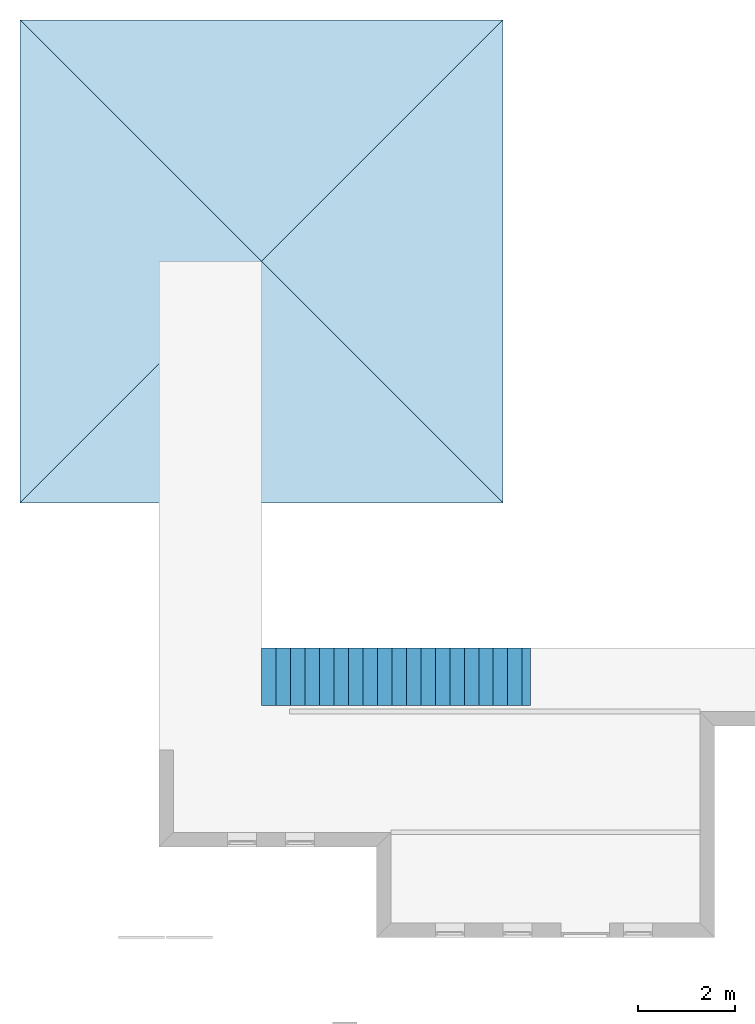
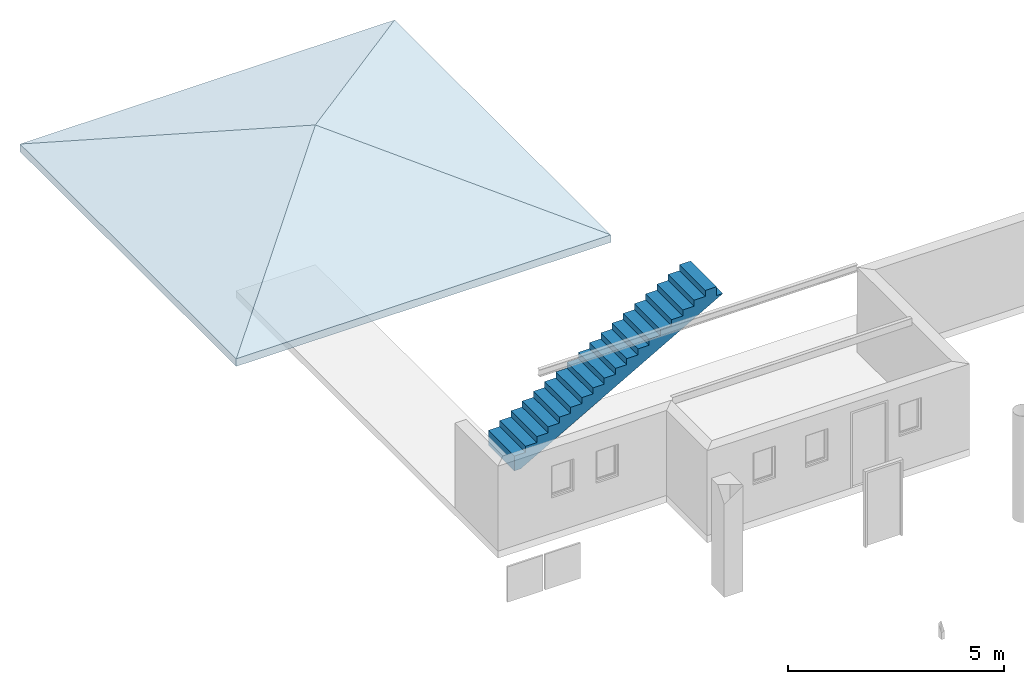
# One storey, part 4 of 5: 1 roof, 1 stair flight.
"""IFC4 building model written with IfcOpenShell, lengths in millimetres."""

from ifc_helpers import new_model, entity, si_unit, converted_unit, frame, origin_with_axes, origin_2d_with_axis, place, context, subcontext, project, spatial, polygons, source, transform, mapped, type_object, type_shapes, element, save


model = new_model("IFC4")

# Units and contexts
model_context = context("Model", 3, precision=1e-05, world=origin_with_axes())
plan_context = context("Plan", 2, precision=1e-05, world=origin_2d_with_axis())
body_context = subcontext(model_context, "Body", "Model", "MODEL_VIEW")
ifc_project = project(units=[si_unit("VOLUMEUNIT", "CUBIC_METRE"), si_unit("LENGTHUNIT", "METRE", prefix="MILLI"), converted_unit("PLANEANGLEUNIT", "degree", entity("IfcReal", 0.0174532925199433), si_unit("PLANEANGLEUNIT", "RADIAN"), dimensions=[0, 0, 0, 0, 0, 0, 0]), si_unit("AREAUNIT", "SQUARE_METRE")], contexts=[model_context, plan_context])

# Site, building, storey
site_placement = place(None, origin_with_axes())
site = spatial("IfcSite", under=ifc_project, at=site_placement)
building_placement = place(site_placement, origin_with_axes())
building = spatial("IfcBuilding", under=site, at=building_placement, Name="Building")
storey_placement = place(building_placement, origin_with_axes())
storey = spatial("IfcBuildingStorey", under=building, at=storey_placement, Name="Storey")

# Stair flight
stair_flight_type = type_object("IfcStairFlightType", PredefinedType="STRAIGHT")
shared_shape_1 = source(origin_with_axes(), body_context, "Body", "Tessellation", [
    polygons([(0.0, 0.0, 0.0), (0.0, 0.0, 170.000015258789), (300.0, 0.0, 170.000015258789), (300.0, 0.0, 340.000030517578), (600.0, 0.0, 340.000030517578), (600.0, 0.0, 510.000030517578), (900.0, 0.0, 510.000030517578), (900.0, 0.0, 680.000061035156), (1200.0, 0.0, 680.000061035156), (1200.0, 0.0, 850.000061035156), (1499.99987792969, 0.0, 850.000061035156), (1499.99987792969, 0.0, 1020.00006103516), (1799.99987792969, 0.0, 1020.00006103516), (1799.99987792969, 0.0, 1190.0), (2099.99975585938, 0.0, 1190.0), (2099.99975585938, 0.0, 1360.00012207031), (2399.99975585938, 0.0, 1360.00012207031), (2399.99975585938, 0.0, 1530.00012207031), (2699.99975585938, 0.0, 1530.00012207031), (2699.99975585938, 0.0, 1700.00024414062), (2999.99951171875, 0.0, 1700.00024414062), (2999.99951171875, 0.0, 1870.00024414062), (3299.99951171875, 0.0, 1870.00024414062), (3299.99951171875, 0.0, 2040.00036621094), (3599.99951171875, 0.0, 2040.00036621094), (3599.99951171875, 0.0, 2210.00048828125), (3899.99951171875, 0.0, 2210.00048828125), (3899.99951171875, 0.0, 2380.00048828125), (4199.99951171875, 0.0, 2380.00048828125), (4199.99951171875, 0.0, 2550.00048828125), (4500.0, 0.0, 2550.00048828125), (4500.0, 0.0, 2720.00073242188), (4800.0, 0.0, 2720.00073242188), (4800.0, 0.0, 2890.00073242188), (5100.0, 0.0, 2890.00073242188), (5100.0, 0.0, 3060.00073242188), (5400.00048828125, 0.0, 3060.00073242188), (5400.00048828125, 0.0, 2810.00073242188), (5567.32861328125, 0.0, 2810.00073242188), (167.327331542969, 0.0, -249.999984741211), (0.0, 0.0, -249.999984741211), (0.0, 1200.0, 170.000015258789), (300.0, 1200.0, 170.000015258789), (300.0, 1200.0, 340.000030517578), (600.0, 1200.0, 340.000030517578), (600.0, 1200.0, 510.000030517578), (900.0, 1200.0, 510.000030517578), (900.0, 1200.0, 680.000061035156), (1200.0, 1200.0, 680.000061035156), (1200.0, 1200.0, 850.000061035156), (1499.99987792969, 1200.0, 850.000061035156), (1499.99987792969, 1200.0, 1020.00006103516), (1799.99987792969, 1200.0, 1020.00006103516), (1799.99987792969, 1200.0, 1190.0), (2099.99975585938, 1200.0, 1190.0), (2099.99975585938, 1200.0, 1360.00012207031), (2399.99975585938, 1200.0, 1360.00012207031), (2399.99975585938, 1200.0, 1530.00012207031), (2699.99975585938, 1200.0, 1530.00012207031), (2699.99975585938, 1200.0, 1700.00024414062), (2999.99951171875, 1200.0, 1700.00024414062), (2999.99951171875, 1200.0, 1870.00024414062), (3299.99951171875, 1200.0, 1870.00024414062), (3299.99951171875, 1200.0, 2040.00036621094), (3599.99951171875, 1200.0, 2040.00036621094), (3599.99951171875, 1200.0, 2210.00048828125), (3899.99951171875, 1200.0, 2210.00048828125), (3899.99951171875, 1200.0, 2380.00048828125), (4199.99951171875, 1200.0, 2380.00048828125), (4199.99951171875, 1200.0, 2550.00048828125), (4500.0, 1200.0, 2550.00048828125), (4500.0, 1200.0, 2720.00073242188), (4800.0, 1200.0, 2720.00073242188), (4800.0, 1200.0, 2890.00073242188), (5100.0, 1200.0, 2890.00073242188), (5100.0, 1200.0, 3060.00073242188), (5400.00048828125, 1200.0, 3060.00073242188), (5400.00048828125, 1200.0, 2810.00073242188), (5567.32861328125, 1200.0, 2810.00073242188), (167.327331542969, 1200.0, -249.999984741211), (0.0, 1200.0, -249.999984741211), (0.0, 1200.0, 0.0)], [[[2, 1, 41, 40, 39, 38, 37, 36, 35, 34, 33, 32, 31, 30, 29, 28, 27, 26, 25, 24, 23, 22, 21, 20, 19, 18, 17, 16, 15, 14, 13, 12, 11, 10, 9, 8, 7, 6, 5, 4, 3]], [[42, 43, 44, 45, 46, 47, 48, 49, 50, 51, 52, 53, 54, 55, 56, 57, 58, 59, 60, 61, 62, 63, 64, 65, 66, 67, 68, 69, 70, 71, 72, 73, 74, 75, 76, 77, 78, 79, 80, 81, 82]], [[8, 9, 49, 48]], [[35, 36, 76, 75]], [[22, 23, 63, 62]], [[9, 10, 50, 49]], [[36, 37, 77, 76]], [[23, 24, 64, 63]], [[10, 11, 51, 50]], [[37, 38, 78, 77]], [[24, 25, 65, 64]], [[11, 12, 52, 51]], [[38, 39, 79, 78]], [[25, 26, 66, 65]], [[12, 13, 53, 52]], [[41, 1, 82, 81]], [[26, 27, 67, 66]], [[13, 14, 54, 53]], [[40, 41, 81, 80]], [[27, 28, 68, 67]], [[14, 15, 55, 54]], [[39, 40, 80, 79]], [[1, 2, 42, 82]], [[28, 29, 69, 68]], [[15, 16, 56, 55]], [[2, 3, 43, 42]], [[29, 30, 70, 69]], [[16, 17, 57, 56]], [[3, 4, 44, 43]], [[30, 31, 71, 70]], [[17, 18, 58, 57]], [[4, 5, 45, 44]], [[31, 32, 72, 71]], [[18, 19, 59, 58]], [[5, 6, 46, 45]], [[32, 33, 73, 72]], [[19, 20, 60, 59]], [[6, 7, 47, 46]], [[33, 34, 74, 73]], [[20, 21, 61, 60]], [[7, 8, 48, 47]], [[34, 35, 75, 74]], [[21, 22, 62, 61]]], closed=True),
])
type_shapes(stair_flight_type, [shared_shape_1])
stair_flight_placement = place(storey_placement, frame((0.0, -1200.00004768372, 0.0), z_axis=(0.0, 0.0, 1.0), x_axis=(1.0, 0.0, 0.0)))
element("IfcStairFlight", 1, at=stair_flight_placement, inside=storey, type_object=stair_flight_type, Name="StairFlight", NumberOfRisers=18, NumberOfTreads=17, PredefinedType="STRAIGHT", RiserHeight=170.000010066562, TreadLength=300.000011920929, context=body_context, shape_type="MappedRepresentation", body=[
    mapped(shared_shape_1, transform((0.0, 0.0, 0.0), x_axis=(1.0, 0.0, 0.0), y_axis=(0.0, 1.0, 0.0), z_axis=(0.0, 0.0, 1.0), scale=1.0)),
])

# Roof
roof_type = type_object("IfcRoofType", PredefinedType="HIP_ROOF")
shared_shape_2 = source(origin_with_axes(), body_context, "Body", "Tessellation", [
    polygons([(-4999.9970703125, -4999.9970703125, 0.0), (4999.9970703125, -4999.9970703125, 0.0), (0.0, 0.0, 1819.84985351562), (4999.9970703125, 4999.9970703125, 0.0), (-4999.9970703125, 4999.9970703125, 0.0), (-4999.9970703125, -4999.9970703125, -212.835525512695), (0.0, 0.0, 1607.01428222656), (4999.9970703125, -4999.9970703125, -212.835525512695), (4999.9970703125, 4999.9970703125, -212.835525512695), (-4999.9970703125, 4999.9970703125, -212.835525512695)], [[[3, 1, 2]], [[2, 4, 3]], [[1, 3, 5]], [[4, 5, 3]], [[6, 7, 8]], [[8, 2, 1]], [[8, 1, 6]], [[8, 7, 9]], [[4, 2, 8]], [[4, 8, 9]], [[10, 7, 6]], [[1, 5, 10]], [[1, 10, 6]], [[9, 7, 10]], [[4, 9, 10]], [[4, 10, 5]]], closed=True),
])
type_shapes(roof_type, [shared_shape_2])
roof_placement = place(storey_placement, frame((0.0, 8000.0, 2118.36528778076), z_axis=(0.0, 0.0, 1.0), x_axis=(1.0, 0.0, 0.0)))
element("IfcRoof", 2, at=roof_placement, inside=storey, type_object=roof_type, Name="Roof", PredefinedType="HIP_ROOF", context=body_context, shape_type="MappedRepresentation", body=[
    mapped(shared_shape_2, transform((0.0, 0.0, 0.0), x_axis=(1.0, 0.0, 0.0), y_axis=(0.0, 1.0, 0.0), z_axis=(0.0, 0.0, 1.0), scale=1.0)),
])

save(model, "model.ifc")
